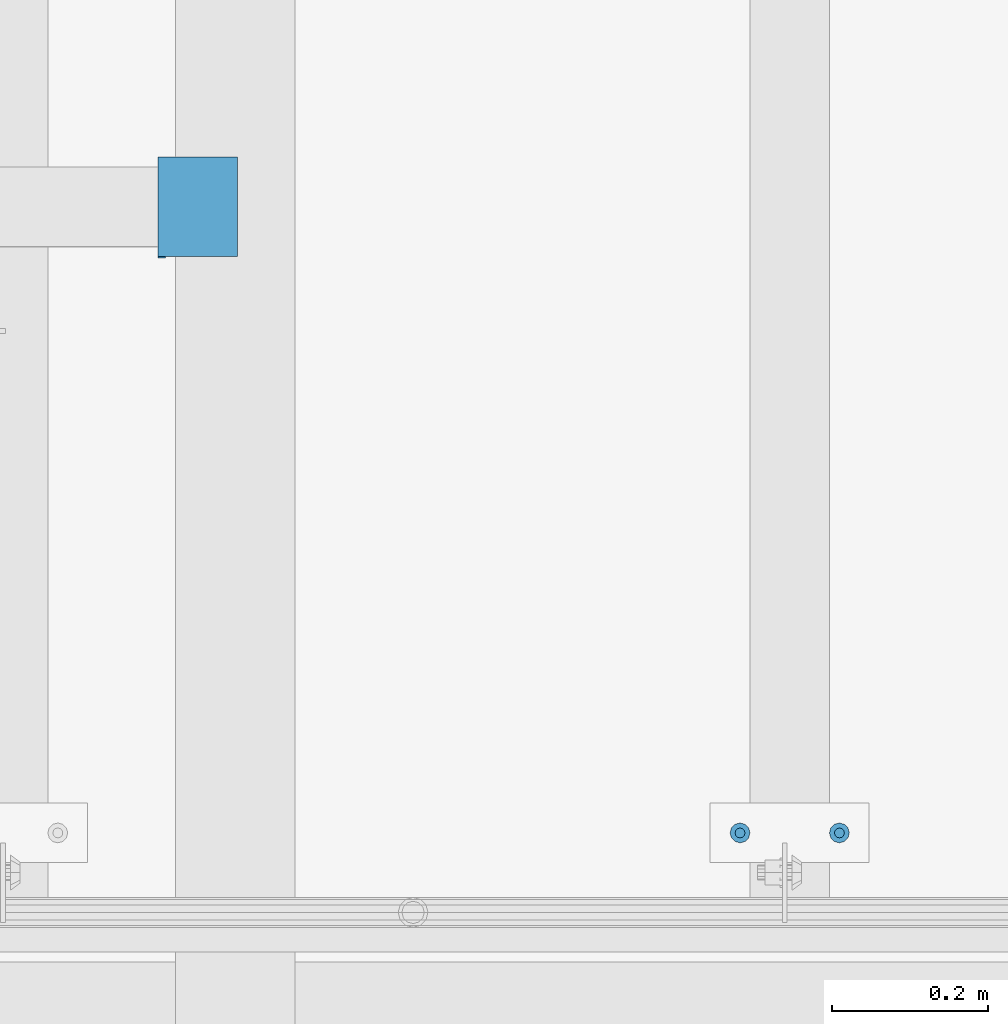
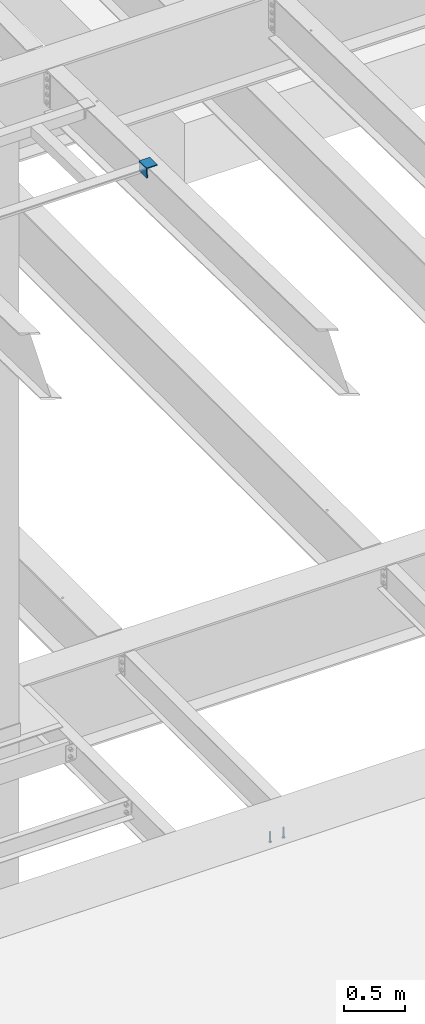
# One storey, part 1250 of 1763: 3 beams, 2 elements without a shape of their own.
"""IFC2X3 building model written with IfcOpenShell, lengths in millimetres."""

from ifc_helpers import new_model, si_unit, frame, origin_with_axes, place, context, subcontext, project, spatial, faceted_brep, material, type_object, element, aggregate, save


model = new_model("IFC2X3")

# Units and contexts
model_context = context("Model", 3, precision=1e-05, world=origin_with_axes())
body_context = subcontext(model_context, "Body", "Model", "MODEL_VIEW")
ifc_project = project(units=[si_unit("LENGTHUNIT", "METRE", prefix="MILLI"), si_unit("AREAUNIT", "SQUARE_METRE"), si_unit("VOLUMEUNIT", "CUBIC_METRE"), si_unit("MASSUNIT", "GRAM", prefix="KILO"), si_unit("TIMEUNIT", "SECOND"), si_unit("PLANEANGLEUNIT", "RADIAN"), si_unit("SOLIDANGLEUNIT", "STERADIAN"), si_unit("THERMODYNAMICTEMPERATUREUNIT", "DEGREE_CELSIUS"), si_unit("LUMINOUSINTENSITYUNIT", "LUMEN")], contexts=[model_context])

# Site, building, storey
site_placement = place(None, origin_with_axes())
site = spatial("IfcSite", under=ifc_project, at=site_placement, CompositionType="ELEMENT")
building_placement = place(site_placement, origin_with_axes())
building = spatial("IfcBuilding", under=site, at=building_placement, Name="Undefined", CompositionType="ELEMENT")
storey_placement = place(building_placement, origin_with_axes())
storey = spatial("IfcBuildingStorey", under=building, at=storey_placement, Name="Undefined", CompositionType="ELEMENT", Elevation=0.0)

# Assembly, beams
assembly_1_placement = place(storey_placement, origin_with_axes())
assembly_1 = element("IfcElementAssembly", 1, at=assembly_1_placement, inside=storey, Name="EMBED PLATE", AssemblyPlace="NOTDEFINED", PredefinedType="RIGID_FRAME")
ifc_material_1 = material(Name="STEEL/A108")
beam_type_1 = type_object("IfcBeamType", PredefinedType="NOTDEFINED")
beam_1_placement = place(assembly_1_placement, frame((-82350.4706100835, 27444.6999954224, 4879.975), z_axis=(1.0, 0.0, 0.0), x_axis=(0.0, 0.0, -1.0)))
beam_1 = element("IfcBeam", 2, at=beam_1_placement, type_object=beam_type_1, material=ifc_material_1, Name="HEADED STUD ANCHOR", context=body_context, shape_type="Brep", body=[
    faceted_brep([(0.0, -3.1800000667572, 5.5), (0.0, -5.5, 3.1800000667572), (94.4880000000003, -5.5, 3.1800000667572), (94.4880000000003, -3.1800000667572, 5.5), (0.0, -6.34999999999491, 1.45519152283669e-11), (94.4880000000003, -6.34999990463257, 0.0), (0.0, -5.5, -3.1800000667572), (94.4880000000003, -5.5, -3.1800000667572), (0.0, -3.1800000667572, -5.5), (94.4880000000003, -3.1800000667572, -5.5), (0.0, 0.0, -6.34999990463257), (94.4880000000003, 0.0, -6.34999990463257), (0.0, 3.1800000667572, -5.5), (94.4880000000003, 3.1800000667572, -5.5), (0.0, 5.5, -3.1800000667572), (94.4880000000003, 5.5, -3.1800000667572), (0.0, 6.34999999999491, -2.91038304567337e-11), (94.4880000000003, 6.34999990463257, 0.0), (0.0, 5.5, 3.1800000667572), (94.4880000000003, 5.5, 3.1800000667572), (0.0, 3.1800000667572, 5.5), (94.4880000000003, 3.1800000667572, 5.5), (0.0, 0.0, 6.34999990463257), (94.4880000000003, 0.0, 6.34999990463257), (96.5200000000004, -10.9899997711182, 6.34999990463257), (96.5200000000004, -6.34000015258789, 10.9899997711182), (96.5200000000004, -12.6999998092651, 0.0), (96.5200000000004, -10.9899997711182, -6.34999990463257), (96.5200000000004, -6.34000015258789, -10.9899997711182), (96.5200000000004, 0.0, -12.6899995803833), (96.5200000000004, 6.34000015258789, -10.9899997711182), (96.5200000000004, 10.9899997711182, -6.34999990463257), (96.5200000000004, 12.6999998092651, 0.0), (96.5200000000004, 10.9899997711182, 6.34999990463257), (96.5200000000004, 6.34000015258789, 10.9899997711182), (96.5200000000004, 0.0, 12.6899995803833), (101.6, -10.9899997711182, 6.34999990463257), (101.6, -6.34000015258789, 10.9899997711182), (101.6, -12.6999998092651, 0.0), (101.6, -10.9899997711182, -6.34999990463257), (101.6, -6.34000015258789, -10.9899997711182), (101.6, 0.0, -12.6899995803833), (101.6, 6.34000015258789, -10.9899997711182), (101.6, 10.9899997711182, -6.34999990463257), (101.6, 12.6999998092651, 0.0), (101.6, 10.9899997711182, 6.34999990463257), (101.6, 6.34000015258789, 10.9899997711182), (101.6, 0.0, 12.6899995803833)], [[[0, 1, 2, 3]], [[1, 4, 5, 2]], [[4, 6, 7, 5]], [[6, 8, 9, 7]], [[8, 10, 11, 9]], [[10, 12, 13, 11]], [[12, 14, 15, 13]], [[14, 16, 17, 15]], [[16, 18, 19, 17]], [[18, 20, 21, 19]], [[20, 22, 23, 21]], [[22, 0, 3, 23]], [[22, 20, 18, 16, 14, 12, 10, 8, 6, 4, 1, 0]], [[3, 2, 24, 25]], [[2, 5, 26, 24]], [[5, 7, 27, 26]], [[7, 9, 28, 27]], [[9, 11, 29, 28]], [[11, 13, 30, 29]], [[13, 15, 31, 30]], [[15, 17, 32, 31]], [[17, 19, 33, 32]], [[19, 21, 34, 33]], [[21, 23, 35, 34]], [[23, 3, 25, 35]], [[25, 24, 36, 37]], [[24, 26, 38, 36]], [[26, 27, 39, 38]], [[27, 28, 40, 39]], [[28, 29, 41, 40]], [[29, 30, 42, 41]], [[30, 31, 43, 42]], [[31, 32, 44, 43]], [[32, 33, 45, 44]], [[33, 34, 46, 45]], [[34, 35, 47, 46]], [[35, 25, 37, 47]], [[38, 39, 40, 41, 42, 43, 44, 45, 46, 47, 37, 36]]]),
])
beam_2_placement = place(assembly_1_placement, frame((-82477.4706070317, 27444.6999954224, 4879.975), z_axis=(1.0, 0.0, 0.0), x_axis=(0.0, 0.0, -1.0)))
beam_2 = element("IfcBeam", 3, at=beam_2_placement, type_object=beam_type_1, material=ifc_material_1, Name="HEADED STUD ANCHOR", context=body_context, shape_type="Brep", body=[
    faceted_brep([(0.0, -3.1800000667572, 5.5), (0.0, -5.5, 3.1800000667572), (94.4880000000003, -5.5, 3.1800000667572), (94.4880000000003, -3.1800000667572, 5.5), (0.0, -6.34999999999491, 1.45519152283669e-11), (94.4880000000003, -6.34999990463257, 0.0), (0.0, -5.5, -3.1800000667572), (94.4880000000003, -5.5, -3.1800000667572), (0.0, -3.1800000667572, -5.5), (94.4880000000003, -3.1800000667572, -5.5), (0.0, 0.0, -6.34999990463257), (94.4880000000003, 0.0, -6.34999990463257), (0.0, 3.1800000667572, -5.5), (94.4880000000003, 3.1800000667572, -5.5), (0.0, 5.5, -3.1800000667572), (94.4880000000003, 5.5, -3.1800000667572), (0.0, 6.34999999999491, -2.91038304567337e-11), (94.4880000000003, 6.34999990463257, 0.0), (0.0, 5.5, 3.1800000667572), (94.4880000000003, 5.5, 3.1800000667572), (0.0, 3.1800000667572, 5.5), (94.4880000000003, 3.1800000667572, 5.5), (0.0, 0.0, 6.34999990463257), (94.4880000000003, 0.0, 6.34999990463257), (96.5200000000004, -10.9899997711182, 6.34999990463257), (96.5200000000004, -6.34000015258789, 10.9899997711182), (96.5200000000004, -12.6999998092651, 0.0), (96.5200000000004, -10.9899997711182, -6.34999990463257), (96.5200000000004, -6.34000015258789, -10.9899997711182), (96.5200000000004, 0.0, -12.6899995803833), (96.5200000000004, 6.34000015258789, -10.9899997711182), (96.5200000000004, 10.9899997711182, -6.34999990463257), (96.5200000000004, 12.6999998092651, 0.0), (96.5200000000004, 10.9899997711182, 6.34999990463257), (96.5200000000004, 6.34000015258789, 10.9899997711182), (96.5200000000004, 0.0, 12.6899995803833), (101.6, -10.9899997711182, 6.34999990463257), (101.6, -6.34000015258789, 10.9899997711182), (101.6, -12.6999998092651, 0.0), (101.6, -10.9899997711182, -6.34999990463257), (101.6, -6.34000015258789, -10.9899997711182), (101.6, 0.0, -12.6899995803833), (101.6, 6.34000015258789, -10.9899997711182), (101.6, 10.9899997711182, -6.34999990463257), (101.6, 12.6999998092651, 0.0), (101.6, 10.9899997711182, 6.34999990463257), (101.6, 6.34000015258789, 10.9899997711182), (101.6, 0.0, 12.6899995803833)], [[[0, 1, 2, 3]], [[1, 4, 5, 2]], [[4, 6, 7, 5]], [[6, 8, 9, 7]], [[8, 10, 11, 9]], [[10, 12, 13, 11]], [[12, 14, 15, 13]], [[14, 16, 17, 15]], [[16, 18, 19, 17]], [[18, 20, 21, 19]], [[20, 22, 23, 21]], [[22, 0, 3, 23]], [[22, 20, 18, 16, 14, 12, 10, 8, 6, 4, 1, 0]], [[3, 2, 24, 25]], [[2, 5, 26, 24]], [[5, 7, 27, 26]], [[7, 9, 28, 27]], [[9, 11, 29, 28]], [[11, 13, 30, 29]], [[13, 15, 31, 30]], [[15, 17, 32, 31]], [[17, 19, 33, 32]], [[19, 21, 34, 33]], [[21, 23, 35, 34]], [[23, 3, 25, 35]], [[25, 24, 36, 37]], [[24, 26, 38, 36]], [[26, 27, 39, 38]], [[27, 28, 40, 39]], [[28, 29, 41, 40]], [[29, 30, 42, 41]], [[30, 31, 43, 42]], [[31, 32, 44, 43]], [[32, 33, 45, 44]], [[33, 34, 46, 45]], [[34, 35, 47, 46]], [[35, 25, 37, 47]], [[38, 39, 40, 41, 42, 43, 44, 45, 46, 47, 37, 36]]]),
])
aggregate(assembly_1, [beam_1, beam_2])

# Assembly, beam
assembly_2_placement = place(storey_placement, origin_with_axes())
assembly_2 = element("IfcElementAssembly", 4, at=assembly_2_placement, inside=storey, Name="ANGLE", AssemblyPlace="NOTDEFINED", PredefinedType="RIGID_FRAME")
ifc_material_2 = material(Name="STEEL/A36")
beam_type_2 = type_object("IfcBeamType", Name="L4X4X3/8", PredefinedType="NOTDEFINED")
beam_3_placement = place(assembly_2_placement, frame((-83170.3680834445, 28307.4311345977, 11284.8763132359), z_axis=(0.0, -0.0209829029927569, -0.999779834654609), x_axis=(0.0, -0.999779834654609, 0.0209829029927566)))
beam_3 = element("IfcBeam", 5, at=beam_3_placement, type_object=beam_type_2, material=ifc_material_2, Name="ANGLE", ObjectType="L4X4X3/8", context=body_context, shape_type="Brep", body=[
    faceted_brep([(-3.63797880709171e-11, 50.8000000000011, -50.8000000000538), (-1.96450855582952e-10, 50.8000000000393, 50.7999999999374), (127.0, 50.7999999999993, 50.7999999999993), (127.0, 50.7999999999993, -50.7999999999993), (0.0, 41.2749999999996, 50.7999999999993), (127.0, 41.2749999999996, 50.7999999999993), (0.0, 41.2749999999996, -41.2750000000015), (127.0, 41.2749999999996, -41.2750000000015), (0.0, -50.7999999999993, -41.2750000000015), (127.0, -50.7999999999993, -41.2750000000015), (2.11002770811319e-10, -50.8000000000357, -50.799999999952), (127.0, -50.7999999999993, -50.7999999999993)], [[[0, 1, 2, 3]], [[1, 4, 5, 2]], [[4, 6, 7, 5]], [[6, 8, 9, 7]], [[8, 10, 11, 9]], [[10, 0, 3, 11]], [[5, 7, 9, 11, 3, 2]], [[10, 8, 6, 4, 1, 0]]]),
])
aggregate(assembly_2, [beam_3])

save(model, "model.ifc")
